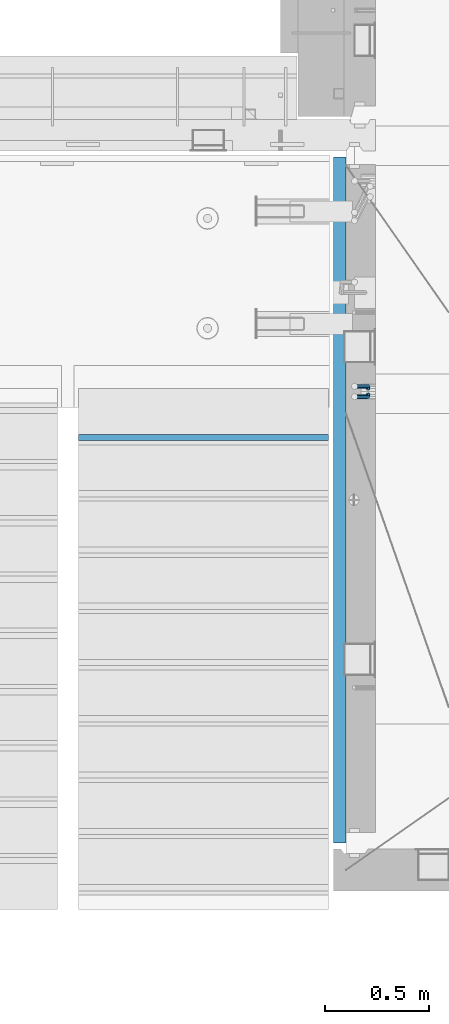
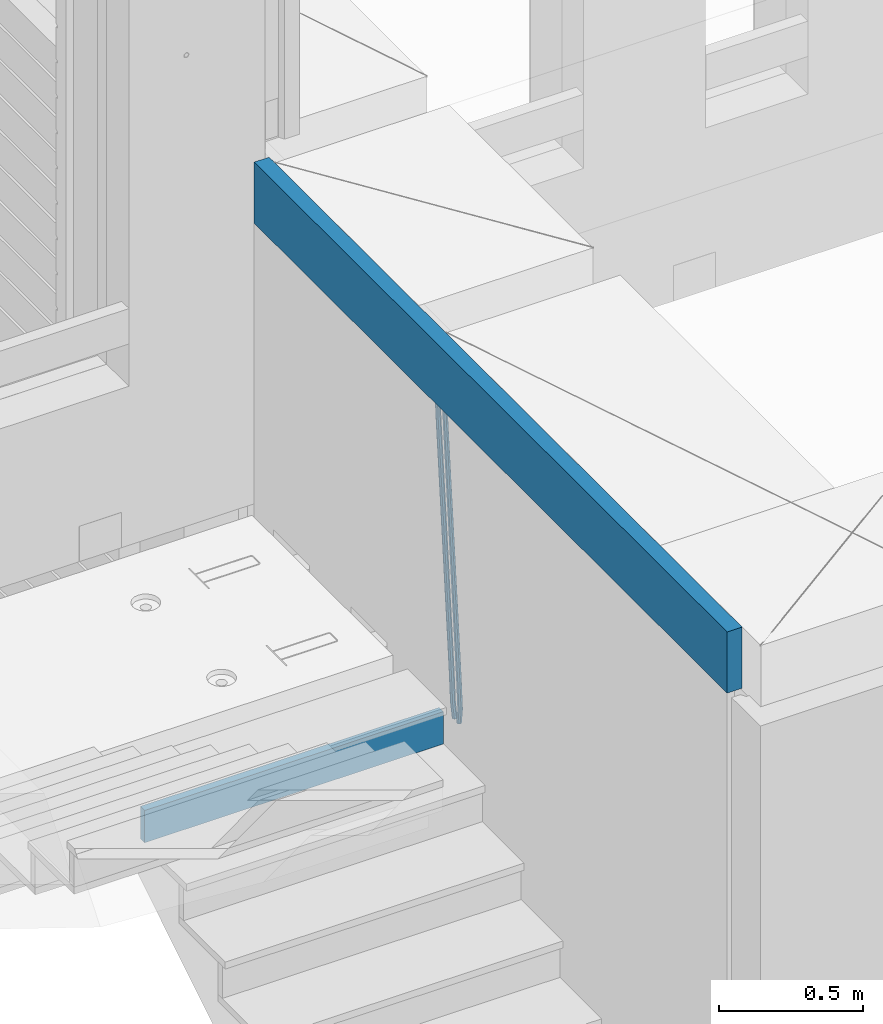
# One storey, part 115 of 341: 4 beams, 2 elements without a shape of their own.
"""IFC2X3 building model written with IfcOpenShell, lengths in millimetres."""

from ifc_helpers import new_model, si_unit, frame, origin_with_axes, place, context, subcontext, project, spatial, faceted_brep, material, type_object, element, aggregate, save


model = new_model("IFC2X3")

# Units and contexts
model_context = context("Model", 3, precision=1e-05, world=origin_with_axes())
body_context = subcontext(model_context, "Body", "Model", "MODEL_VIEW")
ifc_project = project(units=[si_unit("LENGTHUNIT", "METRE", prefix="MILLI"), si_unit("AREAUNIT", "SQUARE_METRE"), si_unit("VOLUMEUNIT", "CUBIC_METRE"), si_unit("MASSUNIT", "GRAM", prefix="KILO"), si_unit("TIMEUNIT", "SECOND"), si_unit("PLANEANGLEUNIT", "RADIAN"), si_unit("SOLIDANGLEUNIT", "STERADIAN"), si_unit("THERMODYNAMICTEMPERATUREUNIT", "DEGREE_CELSIUS"), si_unit("LUMINOUSINTENSITYUNIT", "LUMEN")], contexts=[model_context])

# Site, building, storey
site_placement = place(None, origin_with_axes())
site = spatial("IfcSite", under=ifc_project, at=site_placement, CompositionType="ELEMENT")
building_placement = place(site_placement, origin_with_axes())
building = spatial("IfcBuilding", under=site, at=building_placement, CompositionType="ELEMENT")
storey_placement = place(building_placement, origin_with_axes())
storey = spatial("IfcBuildingStorey", under=building, at=storey_placement, Name="5", CompositionType="ELEMENT", Elevation=0.0)

# Assembly, beams
assembly_1_placement = place(storey_placement, origin_with_axes())
assembly_1 = element("IfcElementAssembly", 1, at=assembly_1_placement, inside=storey, AssemblyPlace="NOTDEFINED", PredefinedType="REINFORCEMENT_UNIT")
ifc_material_1 = material()
beam_type_1 = type_object("IfcBeamType", Name="D20", PredefinedType="NOTDEFINED")
beam_1_placement = place(assembly_1_placement, frame((22375.0000022791, 19290.4700000039, 94985.0), z_axis=(-0.15890508605452, 0.973589036334047, -0.163931577056242), x_axis=(-0.0263727870048703, 0.161796289029781, 0.986471711181718)))
beam_1 = element("IfcBeam", 2, at=beam_1_placement, type_object=beam_type_1, material=ifc_material_1, Name="JM20", ObjectType="D20", context=body_context, shape_type="Brep", body=[
    faceted_brep([(0.0, -10.0, 0.0), (-4.19531716033816e-08, -7.07106781186667, -7.07106781187031), (60.5120847452927, -7.07106784077769, -7.0710678127632), (60.5120847456128, -10.000000028911, -8.96534402272664e-10), (0.0, 0.0, -10.0), (60.5120847479557, -2.89146555587649e-08, -10.0000000008984), (4.196772351861e-08, 7.07106781186303, -7.07106781186667), (60.5120847520593, 7.07106778294838, -7.0710678127632), (0.0, 10.0, 0.0), (60.5120847551734, 9.99999997108898, -8.94715412869118e-10), (4.196772351861e-08, 7.07106781185939, 7.07106781185939), (60.512084755479, 7.07106778295201, 7.07106781097195), (0.0, 0.0, 10.0), (60.512084752816, -2.89110175799578e-08, 9.9999999991071), (-4.19531716033816e-08, -7.07106781187031, 7.07106781185939), (60.5120847487415, -7.07106784077769, 7.07106781096832), (61.1107048256381, -7.07106784106145, -7.07106781277048), (61.616696962592, -10.0000000294385, -9.12905306904577e-10), (61.0120847479702, -2.91511241812259e-08, -10.0000000009038), (61.3786070335627, 7.07106778254092, -7.0710678127723), (61.9955678984406, 9.99999997037958, -9.2018126451876e-10), (62.5015600354091, 7.07106778200614, 7.07106781093921), (62.6001801130624, -2.9907823773101e-08, 9.99999999907436), (62.2336578274699, -7.07106784159623, 7.07106781094103), (61.7013993430301, -7.09359767751084, -7.16550506250837), (62.7066844218498, -10.0415735305724, -0.174261679103211), (61.505464887392, -0.0188181720659486, -10.0788791204338), (62.2336568017054, 7.03845510227256, -7.207768842012), (63.4594101385883, 9.94416717476997, -0.234031689273024), (64.464695217408, 6.99619132171574, 6.75721169413032), (64.6606296730461, -0.0785881837327906, 9.67058575205397), (63.9324377587182, -7.1358614580713, 6.79947547363395), (179.287252569251, -11.5784709304826, -25.9645361348155), (180.292537648071, -14.5264467835441, -18.973292751414), (179.091318113613, -4.50369142503769, -28.877910192741), (179.819510027926, 2.55358184929719, -26.0067999143191), (181.045263364809, 5.45929392180187, -19.033062761582), (182.050548443614, 2.511318068744, -12.0418193781786), (182.246482899252, -4.56346143670453, -9.12844532025679), (181.518290984939, -11.6207347110394, -11.9995555986786), (179.796944029818, -11.5979112078276, -26.0460230258138), (180.785917787493, -14.5452649264626, -19.0521718709458), (179.631039013402, -4.52427706319941, -28.9641980384947), (180.385387646791, 2.53199856077117, -26.0972695639282), (181.618102731314, 5.43744510340548, -19.1246454201662), (182.607076488988, 2.49009138477413, -12.1307942652963), (182.772981505375, -4.58354275985403, -9.21261925261729), (182.018632872001, -11.6398183838246, -12.0795477271802), (180.306575384253, -11.6215474691344, -26.1267734773298), (181.279244090445, -14.5681079330752, -19.1303214631914), (180.170689328603, -4.54931932109321, -29.0497458967745), (180.951186131948, 2.5057611781267, -26.1870011206463), (182.190861352254, 5.41092355571527, -19.2154962132006), (183.16353005846, 2.46436309177807, -12.2190441990567), (183.299416114096, -4.60786505625947, -9.29607177961748), (182.518919310765, -11.662945555483, -12.1588165557403), (300.637581828458, -17.193417372393, -45.2021641841727), (301.610250534635, -20.1399778363302, -38.2057121700307), (300.501695772793, -10.1211892243555, -48.125136603612), (301.282192576138, -3.06610872513556, -45.2623918274874), (302.521867796473, -0.160946347543359, -38.2908869200398), (303.494536502651, -3.10750681148056, -31.2944349058978), (303.630422558286, -10.1797349595217, -28.3714624864531), (302.849925754956, -17.2348154587417, -31.2342072625831), (301.135146648914, -17.2164568742628, -45.2810403078945), (302.103568397841, -20.1628206848691, -38.2839150477537), (301.007079483054, -10.1445907761881, -48.2052522115043), (301.794386909154, -3.08982563961035, -45.3435870847131), (303.035874914756, -0.184747202180006, -38.3723695478091), (304.004296663683, -3.13111101278264, -31.3752442876664), (304.132363829543, -10.2029771108573, -28.4510323840584), (303.345056403443, -17.2577422474315, -31.3126975108532), (301.632689949649, -17.2405558216851, -45.3597353949606), (302.596865217929, -20.1867113775443, -38.3619373656909), (301.512440876206, -10.1690694440185, -48.2851865283189), (302.306558273951, -3.11463305844518, -45.424601167904), (303.549858941391, -0.209639824737678, -38.4536714215171), (304.514034209686, -3.15579538060047, -31.4558733922438), (304.634283283129, -10.2272817582634, -28.5304222588836), (303.840165885384, -17.2817181438368, -31.3910076193022), (1282.62444446853, -64.7506719518351, -200.525713980774), (1283.58861973681, -67.6968275076943, -193.527915951503), (1282.50419539507, -57.6791855741649, -203.451165114133), (1283.29831279283, -50.6247491885915, -200.590579753716), (1284.54161346027, -47.7197559548877, -193.619650007329), (1285.50578872855, -50.6659115107432, -186.621851978058), (1285.62603780199, -57.7373978884098, -183.696400844703), (1284.83192040426, -64.7918342739831, -186.556986205121), (1283.16036625447, -64.7766270183929, -200.610482102403), (1284.18303170854, -67.7256152948248, -193.621935615638), (1282.99823367732, -57.703112193376, -203.529308414698), (1283.79160904189, -50.6486398706256, -200.668605684988), (1285.07574381966, -47.7456242614098, -193.704134774427), (1286.09840927372, -50.6946125378345, -186.715588287659), (1286.26054185088, -57.7681273628514, -183.796761975365), (1285.4671664863, -64.8225996856127, -186.657464705073), (1283.69517474226, -64.7992414390355, -200.702893843656), (1284.77620887742, -67.7506978399178, -193.72443311951), (1283.49124566819, -57.7239592457336, -203.61449796867), (1284.28388054106, -50.6694556112197, -200.753667286384), (1285.60876460234, -47.7681630887928, -193.796237610821), (1286.68979873748, -50.7196194896715, -186.817776886675), (1286.89372781155, -57.7949016829771, -183.906172761662), (1286.10109293868, -64.8494053174909, -186.767003443949), (1305.19726392522, -65.7084590385093, -204.418327587487), (1306.27829806038, -68.6599154393916, -197.43986686334), (1304.99333485115, -58.6331768452073, -207.3299317125), (1305.78596972401, -51.5786732107008, -204.469101030216), (1307.11085378527, -48.6773806882629, -197.511671354648), (1308.19188792045, -51.6288370891452, -190.533210630503), (1308.39581699451, -58.7041192824508, -187.62160650549), (1307.60318212165, -65.758622916961, -190.482437187782), (1305.83218118416, -65.7353065667266, -204.528037531872), (1306.8626665273, -68.6846255078017, -197.540842275655), (1305.64065308902, -58.6605487498273, -207.441784472648), (1306.40027680244, -51.6046492357418, -204.575249657393), (1307.66607505539, -48.7008582650778, -197.607610303868), (1308.69656039854, -51.6501772061529, -190.620415047653), (1308.88808849367, -58.7249350230522, -187.706668106881), (1308.12846478027, -65.7808345371377, -190.573202922138), (1306.46882402551, -65.7602792894941, -204.627733284394), (1307.44862319478, -68.7076100329687, -197.632600773693), (1306.28973061276, -58.6860092309689, -207.543427447275), (1307.01625344875, -51.6288113137889, -204.671709165457), (1308.2228053096, -48.7226963654903, -197.694792061111), (1309.20260447887, -51.6700271089649, -190.699659550409), (1309.38169789161, -58.74429716749, -187.783965387529), (1308.65517505561, -65.80149508467, -190.655683669345), (1405.22131312029, -69.6339088545756, -220.091982741469), (1406.20111228956, -72.5812395980538, -213.096850230768), (1405.04221970754, -62.5596387960541, -223.007676904353), (1405.76874254357, -55.5024408788704, -220.135958622533), (1406.97529440439, -52.5963259305718, -213.159041518189), (1407.95509357366, -55.54365667405, -206.163909007488), (1408.13418698641, -62.6179267325751, -203.248214844601), (1407.40766415041, -69.6751246497552, -206.119933126425)], [[[0, 1, 2, 3]], [[1, 4, 5, 2]], [[4, 6, 7, 5]], [[6, 8, 9, 7]], [[8, 10, 11, 9]], [[10, 12, 13, 11]], [[12, 14, 15, 13]], [[14, 0, 3, 15]], [[14, 12, 10, 8, 6, 4, 1, 0]], [[3, 2, 16, 17]], [[2, 5, 18, 16]], [[5, 7, 19, 18]], [[7, 9, 20, 19]], [[9, 11, 21, 20]], [[11, 13, 22, 21]], [[13, 15, 23, 22]], [[15, 3, 17, 23]], [[17, 16, 24, 25]], [[16, 18, 26, 24]], [[18, 19, 27, 26]], [[19, 20, 28, 27]], [[20, 21, 29, 28]], [[21, 22, 30, 29]], [[22, 23, 31, 30]], [[23, 17, 25, 31]], [[25, 24, 32, 33]], [[24, 26, 34, 32]], [[26, 27, 35, 34]], [[27, 28, 36, 35]], [[28, 29, 37, 36]], [[29, 30, 38, 37]], [[30, 31, 39, 38]], [[31, 25, 33, 39]], [[33, 32, 40, 41]], [[32, 34, 42, 40]], [[34, 35, 43, 42]], [[35, 36, 44, 43]], [[36, 37, 45, 44]], [[37, 38, 46, 45]], [[38, 39, 47, 46]], [[39, 33, 41, 47]], [[41, 40, 48, 49]], [[40, 42, 50, 48]], [[42, 43, 51, 50]], [[43, 44, 52, 51]], [[44, 45, 53, 52]], [[45, 46, 54, 53]], [[46, 47, 55, 54]], [[47, 41, 49, 55]], [[49, 48, 56, 57]], [[48, 50, 58, 56]], [[50, 51, 59, 58]], [[51, 52, 60, 59]], [[52, 53, 61, 60]], [[53, 54, 62, 61]], [[54, 55, 63, 62]], [[55, 49, 57, 63]], [[57, 56, 64, 65]], [[56, 58, 66, 64]], [[58, 59, 67, 66]], [[59, 60, 68, 67]], [[60, 61, 69, 68]], [[61, 62, 70, 69]], [[62, 63, 71, 70]], [[63, 57, 65, 71]], [[65, 64, 72, 73]], [[64, 66, 74, 72]], [[66, 67, 75, 74]], [[67, 68, 76, 75]], [[68, 69, 77, 76]], [[69, 70, 78, 77]], [[70, 71, 79, 78]], [[71, 65, 73, 79]], [[73, 72, 80, 81]], [[72, 74, 82, 80]], [[74, 75, 83, 82]], [[75, 76, 84, 83]], [[76, 77, 85, 84]], [[77, 78, 86, 85]], [[78, 79, 87, 86]], [[79, 73, 81, 87]], [[81, 80, 88, 89]], [[80, 82, 90, 88]], [[82, 83, 91, 90]], [[83, 84, 92, 91]], [[84, 85, 93, 92]], [[85, 86, 94, 93]], [[86, 87, 95, 94]], [[87, 81, 89, 95]], [[89, 88, 96, 97]], [[88, 90, 98, 96]], [[90, 91, 99, 98]], [[91, 92, 100, 99]], [[92, 93, 101, 100]], [[93, 94, 102, 101]], [[94, 95, 103, 102]], [[95, 89, 97, 103]], [[97, 96, 104, 105]], [[96, 98, 106, 104]], [[98, 99, 107, 106]], [[99, 100, 108, 107]], [[100, 101, 109, 108]], [[101, 102, 110, 109]], [[102, 103, 111, 110]], [[103, 97, 105, 111]], [[105, 104, 112, 113]], [[104, 106, 114, 112]], [[106, 107, 115, 114]], [[107, 108, 116, 115]], [[108, 109, 117, 116]], [[109, 110, 118, 117]], [[110, 111, 119, 118]], [[111, 105, 113, 119]], [[113, 112, 120, 121]], [[112, 114, 122, 120]], [[114, 115, 123, 122]], [[115, 116, 124, 123]], [[116, 117, 125, 124]], [[117, 118, 126, 125]], [[118, 119, 127, 126]], [[119, 113, 121, 127]], [[121, 120, 128, 129]], [[120, 122, 130, 128]], [[122, 123, 131, 130]], [[123, 124, 132, 131]], [[124, 125, 133, 132]], [[125, 126, 134, 133]], [[126, 127, 135, 134]], [[127, 121, 129, 135]], [[130, 131, 132, 133, 134, 135, 129, 128]]]),
])
beam_2_placement = place(assembly_1_placement, frame((22375.0000022791, 19260.4700000039, 94985.0), z_axis=(-0.158495816053634, -0.973655762329485, -0.163931488055477), x_axis=(-0.0263727879979646, -0.161796198987477, 0.986471725923465)))
beam_2 = element("IfcBeam", 3, at=beam_2_placement, type_object=beam_type_1, material=ifc_material_1, Name="JM20", ObjectType="D20", context=body_context, shape_type="Brep", body=[
    faceted_brep([(0.0, -10.0, 0.0), (-4.19531716033816e-08, -7.07106781186667, -7.07106781187031), (60.5120052037528, -7.07106781749098, -7.07106782543269), (60.5120052045822, -10.0000000056316, -1.35623849928379e-08), (0.0, 0.0, -10.0), (60.512005203942, -5.62431523576379e-09, -10.0000000135624), (4.196772351861e-08, 7.07106781186303, -7.07106781186667), (60.5120052050625, 7.07106780623872, -7.07106782543269), (0.0, 10.0, 0.0), (60.5120052064449, 9.99999999437205, -1.35623849928379e-08), (4.196772351861e-08, 7.07106781185939, 7.07106781185939), (60.5120052072889, 7.07106780623872, 7.07106779830065), (0.0, 0.0, 10.0), (60.5120052070852, -5.62795321457088e-09, 9.99999998643762), (-4.19531716033816e-08, -7.07106781187031, 7.07106781185939), (60.5120052059501, -7.07106781749098, 7.07106779830065), (61.3783176868601, -7.07106781757102, -7.07106782562914), (61.9952377020818, -10.0000000057662, -1.38970790430903e-08), (61.0120052039565, -5.67160896025598e-09, -10.0000000136788), (61.1108811377926, 7.07106780618051, -7.07106782556366), (61.6170253073215, 9.99999999427382, -1.38097675517201e-08), (62.2339453225432, 7.07106780607864, 7.07106779791502), (62.6002578054613, -5.81712811253965e-09, 9.99999998597195), (62.5013818716106, -7.07106781767652, 7.07106779785681), (62.2331604305218, -7.03851970548931, -7.2077492888784), (63.4588326085068, -9.94427367315438, -0.23401532828575), (61.5053853412101, 0.0187854284049536, -10.0788869429962), (61.7018281175842, 7.09356809489327, -7.16555479231465), (62.7074152454443, 10.041516558791, -0.174343299004249), (63.9330874234438, 7.13576259111869, 6.79939066157385), (64.6608625127556, 0.078457457228069, 9.6705283156989), (64.4644197363668, -6.99632520926025, 6.75719616502465), (179.818932802998, -2.5614449136192, -26.0086288006423), (181.044604980983, -5.46719888128791, -19.034894840057), (179.091157713687, 4.49586022027506, -28.8797664547601), (179.287600490061, 11.5706428867597, -25.9664343040859), (180.293187617921, 14.5185913506575, -18.9752228107754), (181.51885979592, 11.6128373829924, -12.0014888501901), (182.246634885232, 4.55553224909454, -9.13035119606502), (182.050192108843, -2.51925041739014, -12.0436833467465), (180.384803383684, -2.53989940806059, -26.0991062826724), (181.617449868121, -5.44538782921518, -19.126487449299), (179.630864755702, 4.51640954987306, -28.9660606284815), (179.797281007268, 11.5900489573214, -26.0479275136822), (180.786567755189, 14.5373767847341, -19.0541097400928), (182.019214239626, 11.6318883635759, -12.0814909067267), (182.773152867594, 4.5755794056422, -9.21453656090307), (182.606736616028, -2.49806000179888, -12.1326696757169), (180.950594849404, -2.51369963445904, -26.1888475202795), (182.190214025846, -5.41890367426822, -19.2173500092686), (180.170501221772, 4.54141556354443, -29.051616675737), (180.306901410135, 11.613651120846, -26.1286861303379), (181.279894034014, 14.5601873642845, -19.132268955691), (182.519513210456, 11.6549833244717, -12.16077144468), (183.299606838089, 4.59986812646821, -9.29800228921522), (183.163206649726, -2.4723674308334, -12.2209328346216), (301.281596738394, 3.05026059481679, -45.2665532172323), (302.521215914836, 0.145056555003976, -38.2950557062213), (300.501503110776, 10.1053757928166, -48.1293223726971), (300.637903299124, 17.1776113501182, -45.2063918272906), (301.610895923019, 20.1241475935603, -38.2099746526364), (302.850515099461, 17.2189435537439, -31.2384771416328), (303.630608727079, 10.163828355744, -28.375707986168), (303.494208538745, 3.09159279844243, -31.2986385315744), (301.793789297284, 3.07394376027514, -45.3477580501058), (303.035224417355, 0.168823687501572, -38.3765484452742), (301.006883331909, 10.128743964, -48.2094471532764), (301.135465363477, 17.2006180191747, -45.285277089446), (302.104213781728, 20.14695801567, -38.2881870233177), (303.345648901799, 17.2418379429, -31.3169774184789), (304.132554867159, 10.1870377391679, -28.455288315301), (304.003972835591, 3.11516368399316, -31.3794583791459), (302.305958891287, 3.09871749445665, -45.4287821432372), (303.549209831341, 0.193682665365486, -38.4578608624288), (301.512241238641, 10.1531893083702, -48.2893910778876), (301.633005909636, 17.2246841938904, -45.3639817491057), (302.597510597858, 20.1708163533331, -38.3662192661868), (303.840761537926, 17.2657815242455, -31.3952979853784), (304.634479190572, 10.211309710332, -28.5346890507208), (304.513714519577, 3.13981482481177, -31.4600983795099), (1283.29235311947, 50.544232039254, -200.613633821762), (1284.53560405952, 47.6391972101628, -193.642712540946), (1282.49863546679, 57.5987038531639, -203.474242756405), (1282.6194001378, 64.6701987386878, -200.548833427623), (1283.58390482602, 67.6163308981268, -193.551070944704), (1284.82715576609, 64.7112960690356, -186.580149663889), (1285.62087341874, 57.6568242551293, -183.719540729246), (1285.50010874774, 50.5853293696091, -186.644950058035), (1283.86584870378, 50.5719692160856, -200.704356616399), (1285.05399320807, 47.6642691581874, -193.72471790167), (1283.12497041782, 57.628996611762, -203.573324351266), (1283.26535480202, 64.701440406865, -200.651018717188), (1284.20476658808, 67.6463589453451, -193.649286721222), (1285.39291109238, 64.7386588874433, -186.6696480065), (1286.13378937833, 57.6816314917669, -183.800680271634), (1285.99340499415, 50.6091876966675, -186.722985905704), (1284.44060590031, 50.5936921758439, -200.788496023008), (1285.57352274218, 47.68390478734, -193.800772463459), (1283.75268322045, 57.6527210297136, -203.665215993606), (1283.91273047855, 64.7259079835276, -200.745788831606), (1284.82699416149, 67.6698760489453, -193.740375374167), (1285.95991100336, 64.7600886604341, -186.752651814619), (1286.64783368325, 57.7010598065717, -183.875931844028), (1286.48778642512, 50.6278728527504, -186.795359006021), (1306.02894027183, 51.4096237058839, -203.948838607132), (1307.16185711371, 48.4998363173727, -196.961115047583), (1305.34101759194, 58.4686525597535, -206.825558577722), (1305.50106485008, 65.5418395135639, -203.90613141573), (1306.415328533, 68.4858075789816, -196.900717958291), (1307.54824537487, 65.5760201904777, -189.912994398743), (1308.23616805475, 58.5169913366044, -187.036274428152), (1308.07612079663, 51.4438043827904, -189.955701590145), (1306.55429855913, 51.4294796328759, -204.025746447209), (1307.74597489809, 48.5219130607366, -197.046624762064), (1305.83539902292, 58.4873377158401, -206.897931678046), (1306.0103978878, 65.5610897659317, -203.980693299985), (1306.97678319212, 68.507027769072, -196.982909990227), (1308.16845953107, 65.5994611969327, -190.00378830509), (1308.88735906727, 58.5416031139684, -187.131603074253), (1308.71236020241, 51.4678510638769, -190.048841452306), (1307.07832423707, 51.4505295560484, -204.110977857723), (1308.32861102538, 48.5453173445967, -197.141389009383), (1306.32852641959, 58.507146466156, -206.978137563652), (1306.51843896537, 65.5814975934481, -204.063324856921), (1307.5368136808, 68.5295239925508, -197.073997489359), (1308.78710046913, 65.6243117811064, -190.104408641026), (1309.53689828661, 58.5676948709952, -187.237248935096), (1309.34698574082, 51.4933437436994, -190.152061641827), (1405.73383542724, 55.413485988287, -220.157039583137), (1406.98412221558, 52.5082737768425, -213.187450734797), (1404.98403760976, 62.4701028983982, -223.024199289066), (1405.17395015556, 69.544454025694, -220.109386582335), (1406.19232487098, 72.492480424793, -213.12005921478), (1407.44261165931, 69.5872682133449, -206.15047036644), (1408.1924094768, 62.5306513032374, -203.28331066051), (1408.00249693099, 55.4563001759452, -206.198123367241)], [[[0, 1, 2, 3]], [[1, 4, 5, 2]], [[4, 6, 7, 5]], [[6, 8, 9, 7]], [[8, 10, 11, 9]], [[10, 12, 13, 11]], [[12, 14, 15, 13]], [[14, 0, 3, 15]], [[14, 12, 10, 8, 6, 4, 1, 0]], [[3, 2, 16, 17]], [[2, 5, 18, 16]], [[5, 7, 19, 18]], [[7, 9, 20, 19]], [[9, 11, 21, 20]], [[11, 13, 22, 21]], [[13, 15, 23, 22]], [[15, 3, 17, 23]], [[17, 16, 24, 25]], [[16, 18, 26, 24]], [[18, 19, 27, 26]], [[19, 20, 28, 27]], [[20, 21, 29, 28]], [[21, 22, 30, 29]], [[22, 23, 31, 30]], [[23, 17, 25, 31]], [[25, 24, 32, 33]], [[24, 26, 34, 32]], [[26, 27, 35, 34]], [[27, 28, 36, 35]], [[28, 29, 37, 36]], [[29, 30, 38, 37]], [[30, 31, 39, 38]], [[31, 25, 33, 39]], [[33, 32, 40, 41]], [[32, 34, 42, 40]], [[34, 35, 43, 42]], [[35, 36, 44, 43]], [[36, 37, 45, 44]], [[37, 38, 46, 45]], [[38, 39, 47, 46]], [[39, 33, 41, 47]], [[41, 40, 48, 49]], [[40, 42, 50, 48]], [[42, 43, 51, 50]], [[43, 44, 52, 51]], [[44, 45, 53, 52]], [[45, 46, 54, 53]], [[46, 47, 55, 54]], [[47, 41, 49, 55]], [[49, 48, 56, 57]], [[48, 50, 58, 56]], [[50, 51, 59, 58]], [[51, 52, 60, 59]], [[52, 53, 61, 60]], [[53, 54, 62, 61]], [[54, 55, 63, 62]], [[55, 49, 57, 63]], [[57, 56, 64, 65]], [[56, 58, 66, 64]], [[58, 59, 67, 66]], [[59, 60, 68, 67]], [[60, 61, 69, 68]], [[61, 62, 70, 69]], [[62, 63, 71, 70]], [[63, 57, 65, 71]], [[65, 64, 72, 73]], [[64, 66, 74, 72]], [[66, 67, 75, 74]], [[67, 68, 76, 75]], [[68, 69, 77, 76]], [[69, 70, 78, 77]], [[70, 71, 79, 78]], [[71, 65, 73, 79]], [[73, 72, 80, 81]], [[72, 74, 82, 80]], [[74, 75, 83, 82]], [[75, 76, 84, 83]], [[76, 77, 85, 84]], [[77, 78, 86, 85]], [[78, 79, 87, 86]], [[79, 73, 81, 87]], [[81, 80, 88, 89]], [[80, 82, 90, 88]], [[82, 83, 91, 90]], [[83, 84, 92, 91]], [[84, 85, 93, 92]], [[85, 86, 94, 93]], [[86, 87, 95, 94]], [[87, 81, 89, 95]], [[89, 88, 96, 97]], [[88, 90, 98, 96]], [[90, 91, 99, 98]], [[91, 92, 100, 99]], [[92, 93, 101, 100]], [[93, 94, 102, 101]], [[94, 95, 103, 102]], [[95, 89, 97, 103]], [[97, 96, 104, 105]], [[96, 98, 106, 104]], [[98, 99, 107, 106]], [[99, 100, 108, 107]], [[100, 101, 109, 108]], [[101, 102, 110, 109]], [[102, 103, 111, 110]], [[103, 97, 105, 111]], [[105, 104, 112, 113]], [[104, 106, 114, 112]], [[106, 107, 115, 114]], [[107, 108, 116, 115]], [[108, 109, 117, 116]], [[109, 110, 118, 117]], [[110, 111, 119, 118]], [[111, 105, 113, 119]], [[113, 112, 120, 121]], [[112, 114, 122, 120]], [[114, 115, 123, 122]], [[115, 116, 124, 123]], [[116, 117, 125, 124]], [[117, 118, 126, 125]], [[118, 119, 127, 126]], [[119, 113, 121, 127]], [[121, 120, 128, 129]], [[120, 122, 130, 128]], [[122, 123, 131, 130]], [[123, 124, 132, 131]], [[124, 125, 133, 132]], [[125, 126, 134, 133]], [[126, 127, 135, 134]], [[127, 121, 129, 135]], [[130, 131, 132, 133, 134, 135, 129, 128]]]),
])
ifc_material_2 = material(Name="CONCRETE/C25/30")
beam_type_2 = type_object("IfcBeamType", Name="260X60", PredefinedType="NOTDEFINED")
beam_3_placement = place(assembly_1_placement, frame((22240.0000000001, 20400.0, 96600.0), z_axis=(0.0, 0.0, 1.0), x_axis=(0.0, -1.0, 0.0)))
beam_3 = element("IfcBeam", 4, at=beam_3_placement, type_object=beam_type_2, material=ifc_material_2, ObjectType="260X60", context=body_context, shape_type="Brep", body=[
    faceted_brep([(0.0, 30.0, -130.0), (0.0, 30.0, 130.0), (3290.0, 30.0, 130.0), (3290.0, 30.0, -130.0), (0.0, -30.0, 130.0), (3290.0, -30.0, 130.0), (0.0, -30.0, -130.0), (3290.0, -30.0, -130.0)], [[[0, 1, 2, 3]], [[1, 4, 5, 2]], [[4, 6, 7, 5]], [[6, 0, 3, 7]], [[5, 7, 3, 2]], [[6, 4, 1, 0]]]),
])
aggregate(assembly_1, [beam_1, beam_2, beam_3])

# Assembly, beam
assembly_2_placement = place(storey_placement, origin_with_axes())
assembly_2 = element("IfcElementAssembly", 5, at=assembly_2_placement, inside=storey, Name="E9", AssemblyPlace="NOTDEFINED", PredefinedType="NOTDEFINED")
ifc_material_3 = material(Name="Undefined/C32/40")
beam_type_3 = type_object("IfcBeamType", PredefinedType="NOTDEFINED")
beam_4_placement = place(assembly_2_placement, frame((20985.002175553, 19055.001025346, 95161.803607297), z_axis=(0.0, -1.0, 0.0), x_axis=(1.0, 0.0, 0.0)))
beam_4 = element("IfcBeam", 6, at=beam_4_placement, type_object=beam_type_3, material=ifc_material_3, Name="E9", context=body_context, shape_type="Brep", body=[
    faceted_brep([(0.0, 68.5, -15.0), (0.0, 68.5, 15.0), (1200.0, 68.5, 15.0), (1200.0, 68.5, -15.0), (0.0, -68.5, 15.0), (1200.0, -68.5, 15.0), (0.0, -68.5, -15.0), (1200.0, -68.5, -15.0)], [[[0, 1, 2, 3]], [[1, 4, 5, 2]], [[4, 6, 7, 5]], [[6, 0, 3, 7]], [[5, 7, 3, 2]], [[6, 4, 1, 0]]]),
])
aggregate(assembly_2, [beam_4])

save(model, "model.ifc")
